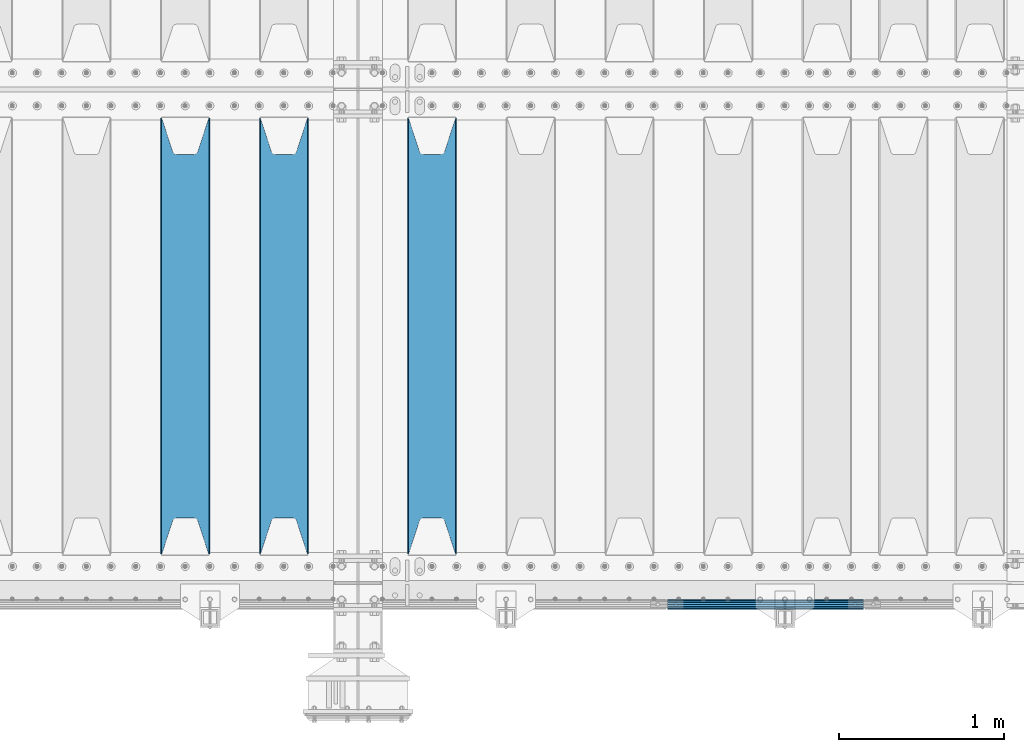
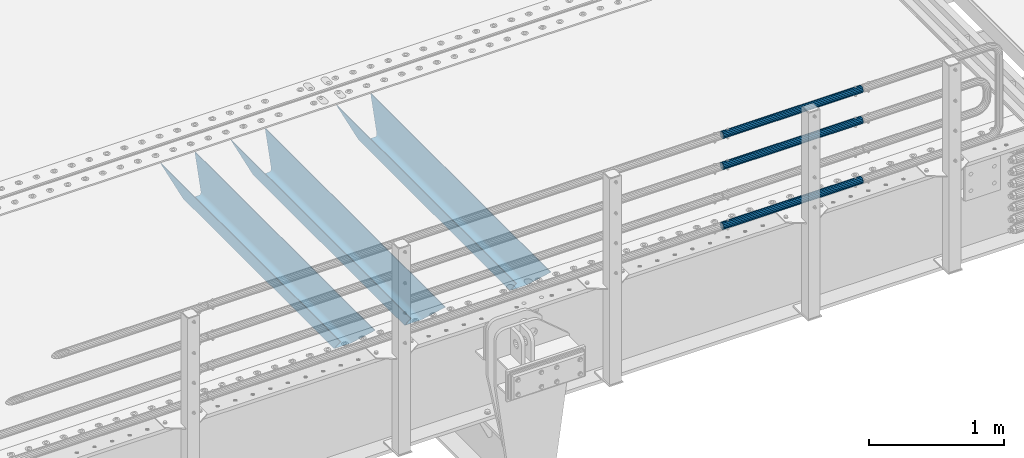
# One storey, part 109 of 257: 6 beams.
"""IFC2X3 building model written with IfcOpenShell, lengths in millimetres."""

from ifc_helpers import new_model, si_unit, frame, origin_with_axes, place, context, subcontext, project, spatial, faceted_brep, material, type_object, element, save


model = new_model("IFC2X3")

# Units and contexts
model_context = context("Model", 3, precision=1e-05, world=origin_with_axes())
body_context = subcontext(model_context, "Body", "Model", "MODEL_VIEW")
ifc_project = project(units=[si_unit("LENGTHUNIT", "METRE", prefix="MILLI"), si_unit("AREAUNIT", "SQUARE_METRE"), si_unit("VOLUMEUNIT", "CUBIC_METRE"), si_unit("MASSUNIT", "GRAM", prefix="KILO"), si_unit("TIMEUNIT", "SECOND"), si_unit("PLANEANGLEUNIT", "RADIAN"), si_unit("SOLIDANGLEUNIT", "STERADIAN"), si_unit("THERMODYNAMICTEMPERATUREUNIT", "DEGREE_CELSIUS"), si_unit("LUMINOUSINTENSITYUNIT", "LUMEN")], contexts=[model_context])

# Site, building, storey
site_placement = place(None, origin_with_axes())
site = spatial("IfcSite", under=ifc_project, at=site_placement, CompositionType="ELEMENT")
building_placement = place(site_placement, origin_with_axes())
building = spatial("IfcBuilding", under=site, at=building_placement, Name="Standard", CompositionType="ELEMENT")
storey_placement = place(building_placement, origin_with_axes())
storey = spatial("IfcBuildingStorey", under=building, at=storey_placement, Name="Undefined", CompositionType="ELEMENT", Elevation=0.0)

# Beams
ifc_material_1 = material(Name="STEEL/S355N")
beam_type_1 = type_object("IfcBeamType", PredefinedType="NOTDEFINED")
beam_1_placement = place(storey_placement, frame((55150.0, 175.0, -115.0), z_axis=(0.0, 0.0, 1.0), x_axis=(0.0, 1.0, 0.0)))
element("IfcBeam", 1, at=beam_1_placement, inside=storey, type_object=beam_type_1, material=ifc_material_1, context=body_context, shape_type="Brep", body=[
    faceted_brep([(0.0, 150.0, 115.0), (0.0, 143.690000000002, 115.0), (2650.00000000297, 143.690000000002, 115.0), (2650.00000000297, 150.0, 115.0), (2650.00000000297, 142.059565218406, 110.0000000031), (2650.00000000297, 148.369565218403, 110.0000000031), (2441.90079219208, -80.1103600731149, -98.0992078077845), (2437.7588105432, -77.5672621345584, -102.241189456673), (2434.06523489746, -74.4080125315522, -105.934765102404), (2430.91086095089, -70.7102721255724, -109.089139048974), (2428.37322971128, -66.5649389910031, -111.626770288588), (2426.51472138055, -62.0739139532889, -113.485278619323), (2425.38102192091, -57.3475956567636, -114.618978078955), (2424.99999999987, -52.5021667386536, -115.0), (2424.99999999987, 52.5021667386536, -115.0), (2425.38102192091, 57.3475956567636, -114.618978078955), (2426.51472138055, 62.0739139532889, -113.485278619323), (2428.37322971128, 66.5649389910031, -111.626770288588), (2430.91086095089, 70.7102721255724, -109.089139048974), (2434.06523489746, 74.4080125315522, -105.934765102404), (2437.7588105432, 77.5672621345584, -102.241189456673), (2441.90079219208, 80.1103600731149, -98.0992078077846), (2446.38936140511, 81.9747917625791, -93.6106385947584), (2448.24948500409, 76.2713538057287, -91.7505149957729), (2444.62967112262, 74.76777986261, -95.3703288772456), (2441.28936334126, 72.7168944282894, -98.710636658607), (2438.31067330438, 70.1691124903809, -101.689326695487), (2435.76682334747, 67.1870637758839, -104.233176652398), (2433.72034654133, 63.8440531834931, -106.279653458539), (2432.22154950041, 60.2222587982324, -107.778450499454), (2431.30727574265, 56.4107117849126, -108.692724257221), (2430.99999999987, 52.5031078186876, -109.0), (2430.99999999987, -52.5031078186876, -109.0), (2431.30727574265, -56.4107117849126, -108.692724257221), (2432.22154950041, -60.2222587982324, -107.778450499454), (2433.72034654133, -63.8440531834931, -106.279653458539), (2435.76682334747, -67.1870637758839, -104.233176652398), (2438.31067330438, -70.1691124903809, -101.689326695487), (2441.28936334126, -72.7168944282894, -98.7106366586071), (2444.62967112262, -74.76777986261, -95.3703288772457), (2448.24948500409, -76.2713538057287, -91.7505149957729), (2650.00000000297, -142.059565218406, 110.0000000031), (2650.00000000297, -148.369565218403, 110.0000000031), (2446.38936140511, -81.9747917625791, -93.6106385947584), (2650.00000000297, -143.690000000002, 115.0), (2650.00000000297, -150.0, 115.0), (0.0, -143.690000000002, 115.0), (0.0, -150.0, 115.0), (0.0, -148.369565218258, 110.000000002662), (203.61063859742, -81.9747917625791, -93.6106385947584), (208.099207810447, -80.1103600731149, -98.0992078077845), (212.241189459335, -77.5672621345584, -102.241189456673), (215.934765105066, -74.4080125315522, -105.934765102404), (219.089139051636, -70.7102721255724, -109.089139048974), (221.626770291251, -66.5649389910031, -111.626770288588), (223.485278621985, -62.0739139532889, -113.485278619323), (224.618978081617, -57.3475956567636, -114.618978078955), (225.000000002662, -52.5021667386536, -115.0), (225.000000002662, 52.5021667386536, -115.0), (224.618978081617, 57.3475956567636, -114.618978078955), (223.485278621985, 62.0739139532889, -113.485278619323), (221.626770291251, 66.5649389910031, -111.626770288588), (219.089139051636, 70.7102721255724, -109.089139048974), (215.934765105066, 74.4080125315522, -105.934765102404), (212.241189459335, 77.5672621345584, -102.241189456673), (208.099207810447, 80.1103600731149, -98.0992078077846), (203.61063859742, 81.9747917625791, -93.6106385947584), (0.0, 148.369565218258, 110.000000002662), (0.0, 142.05956521826, 110.000000002662), (201.750514998435, 76.2713538057287, -91.7505149957729), (205.370328879908, 74.76777986261, -95.3703288772456), (208.710636661269, 72.7168944282894, -98.710636658607), (211.689326698149, 70.1691124903809, -101.689326695487), (214.233176655061, 67.1870637758839, -104.233176652398), (216.279653461201, 63.8440531834931, -106.279653458539), (217.778450502116, 60.2222587982324, -107.778450499454), (218.692724259884, 56.4107117849126, -108.692724257221), (219.000000002662, 52.5031078186876, -109.0), (219.000000002662, -52.5031078186876, -109.0), (218.692724259884, -56.4107117849126, -108.692724257221), (217.778450502116, -60.2222587982324, -107.778450499454), (216.279653461201, -63.8440531834931, -106.279653458539), (214.233176655061, -67.1870637758839, -104.233176652398), (211.689326698149, -70.1691124903809, -101.689326695487), (208.710636661269, -72.7168944282894, -98.7106366586071), (205.370328879908, -74.76777986261, -95.3703288772457), (201.750514998435, -76.2713538057287, -91.7505149957729), (0.0, -142.05956521826, 110.000000002662)], [[[0, 1, 2, 3]], [[3, 2, 4, 5]], [[6, 7, 8, 9, 10, 11, 12, 13, 14, 15, 16, 17, 18, 19, 20, 21, 22, 5, 4, 23, 24, 25, 26, 27, 28, 29, 30, 31, 32, 33, 34, 35, 36, 37, 38, 39, 40, 41, 42, 43]], [[44, 45, 42, 41]], [[46, 47, 45, 44]], [[43, 42, 45, 47, 48, 49]], [[6, 43, 49, 50]], [[7, 6, 50, 51]], [[8, 7, 51, 52]], [[9, 8, 52, 53]], [[10, 9, 53, 54]], [[11, 10, 54, 55]], [[12, 11, 55, 56]], [[13, 12, 56, 57]], [[14, 13, 57, 58]], [[15, 14, 58, 59]], [[16, 15, 59, 60]], [[17, 16, 60, 61]], [[18, 17, 61, 62]], [[19, 18, 62, 63]], [[20, 19, 63, 64]], [[21, 20, 64, 65]], [[22, 21, 65, 66]], [[0, 3, 5, 22, 66, 67]], [[1, 0, 67, 68]], [[23, 4, 2, 1, 68, 69]], [[24, 23, 69, 70]], [[25, 24, 70, 71]], [[26, 25, 71, 72]], [[27, 26, 72, 73]], [[28, 27, 73, 74]], [[29, 28, 74, 75]], [[30, 29, 75, 76]], [[31, 30, 76, 77]], [[32, 31, 77, 78]], [[33, 32, 78, 79]], [[34, 33, 79, 80]], [[35, 34, 80, 81]], [[36, 35, 81, 82]], [[37, 36, 82, 83]], [[38, 37, 83, 84]], [[39, 38, 84, 85]], [[40, 39, 85, 86]], [[46, 44, 41, 40, 86, 87]], [[47, 46, 87, 48]], [[86, 85, 84, 83, 82, 81, 80, 79, 78, 77, 76, 75, 74, 73, 72, 71, 70, 69, 68, 67, 66, 65, 64, 63, 62, 61, 60, 59, 58, 57, 56, 55, 54, 53, 52, 51, 50, 49, 48, 87]]]),
])
beam_2_placement = place(storey_placement, frame((54250.0, 175.0, -115.0), z_axis=(0.0, 0.0, 1.0), x_axis=(0.0, 1.0, 0.0)))
element("IfcBeam", 2, at=beam_2_placement, inside=storey, type_object=beam_type_1, material=ifc_material_1, context=body_context, shape_type="Brep", body=[
    faceted_brep([(0.0, 150.0, 115.0), (0.0, 143.690000000002, 115.0), (2650.00000000297, 143.690000000002, 115.0), (2650.00000000297, 150.0, 115.0), (2650.00000000297, 142.059565218406, 110.0000000031), (2650.00000000297, 148.369565218403, 110.0000000031), (2441.90079219208, -80.1103600731149, -98.0992078077845), (2437.7588105432, -77.5672621345584, -102.241189456673), (2434.06523489746, -74.4080125315522, -105.934765102404), (2430.91086095089, -70.7102721255724, -109.089139048974), (2428.37322971128, -66.5649389910031, -111.626770288588), (2426.51472138055, -62.0739139532889, -113.485278619323), (2425.38102192091, -57.3475956567636, -114.618978078955), (2424.99999999987, -52.5021667386536, -115.0), (2424.99999999987, 52.5021667386536, -115.0), (2425.38102192091, 57.3475956567636, -114.618978078955), (2426.51472138055, 62.0739139532889, -113.485278619323), (2428.37322971128, 66.5649389910031, -111.626770288588), (2430.91086095089, 70.7102721255724, -109.089139048974), (2434.06523489746, 74.4080125315522, -105.934765102404), (2437.7588105432, 77.5672621345584, -102.241189456673), (2441.90079219208, 80.1103600731149, -98.0992078077846), (2446.38936140511, 81.9747917625791, -93.6106385947584), (2448.24948500409, 76.2713538057287, -91.7505149957729), (2444.62967112262, 74.76777986261, -95.3703288772456), (2441.28936334126, 72.7168944282894, -98.710636658607), (2438.31067330438, 70.1691124903809, -101.689326695487), (2435.76682334747, 67.1870637758839, -104.233176652398), (2433.72034654133, 63.8440531834931, -106.279653458539), (2432.22154950041, 60.2222587982324, -107.778450499454), (2431.30727574265, 56.4107117849126, -108.692724257221), (2430.99999999987, 52.5031078186876, -109.0), (2430.99999999987, -52.5031078186876, -109.0), (2431.30727574265, -56.4107117849126, -108.692724257221), (2432.22154950041, -60.2222587982324, -107.778450499454), (2433.72034654133, -63.8440531834931, -106.279653458539), (2435.76682334747, -67.1870637758839, -104.233176652398), (2438.31067330438, -70.1691124903809, -101.689326695487), (2441.28936334126, -72.7168944282894, -98.7106366586071), (2444.62967112262, -74.76777986261, -95.3703288772457), (2448.24948500409, -76.2713538057287, -91.7505149957729), (2650.00000000297, -142.059565218406, 110.0000000031), (2650.00000000297, -148.369565218403, 110.0000000031), (2446.38936140511, -81.9747917625791, -93.6106385947584), (2650.00000000297, -143.690000000002, 115.0), (2650.00000000297, -150.0, 115.0), (0.0, -143.690000000002, 115.0), (0.0, -150.0, 115.0), (0.0, -148.369565218258, 110.000000002662), (203.61063859742, -81.9747917625791, -93.6106385947584), (208.099207810447, -80.1103600731149, -98.0992078077845), (212.241189459335, -77.5672621345584, -102.241189456673), (215.934765105066, -74.4080125315522, -105.934765102404), (219.089139051636, -70.7102721255724, -109.089139048974), (221.626770291251, -66.5649389910031, -111.626770288588), (223.485278621985, -62.0739139532889, -113.485278619323), (224.618978081617, -57.3475956567636, -114.618978078955), (225.000000002662, -52.5021667386536, -115.0), (225.000000002662, 52.5021667386536, -115.0), (224.618978081617, 57.3475956567636, -114.618978078955), (223.485278621985, 62.0739139532889, -113.485278619323), (221.626770291251, 66.5649389910031, -111.626770288588), (219.089139051636, 70.7102721255724, -109.089139048974), (215.934765105066, 74.4080125315522, -105.934765102404), (212.241189459335, 77.5672621345584, -102.241189456673), (208.099207810447, 80.1103600731149, -98.0992078077846), (203.61063859742, 81.9747917625791, -93.6106385947584), (0.0, 148.369565218258, 110.000000002662), (0.0, 142.05956521826, 110.000000002662), (201.750514998435, 76.2713538057287, -91.7505149957729), (205.370328879908, 74.76777986261, -95.3703288772456), (208.710636661269, 72.7168944282894, -98.710636658607), (211.689326698149, 70.1691124903809, -101.689326695487), (214.233176655061, 67.1870637758839, -104.233176652398), (216.279653461201, 63.8440531834931, -106.279653458539), (217.778450502116, 60.2222587982324, -107.778450499454), (218.692724259884, 56.4107117849126, -108.692724257221), (219.000000002662, 52.5031078186876, -109.0), (219.000000002662, -52.5031078186876, -109.0), (218.692724259884, -56.4107117849126, -108.692724257221), (217.778450502116, -60.2222587982324, -107.778450499454), (216.279653461201, -63.8440531834931, -106.279653458539), (214.233176655061, -67.1870637758839, -104.233176652398), (211.689326698149, -70.1691124903809, -101.689326695487), (208.710636661269, -72.7168944282894, -98.7106366586071), (205.370328879908, -74.76777986261, -95.3703288772457), (201.750514998435, -76.2713538057287, -91.7505149957729), (0.0, -142.05956521826, 110.000000002662)], [[[0, 1, 2, 3]], [[3, 2, 4, 5]], [[6, 7, 8, 9, 10, 11, 12, 13, 14, 15, 16, 17, 18, 19, 20, 21, 22, 5, 4, 23, 24, 25, 26, 27, 28, 29, 30, 31, 32, 33, 34, 35, 36, 37, 38, 39, 40, 41, 42, 43]], [[44, 45, 42, 41]], [[46, 47, 45, 44]], [[43, 42, 45, 47, 48, 49]], [[6, 43, 49, 50]], [[7, 6, 50, 51]], [[8, 7, 51, 52]], [[9, 8, 52, 53]], [[10, 9, 53, 54]], [[11, 10, 54, 55]], [[12, 11, 55, 56]], [[13, 12, 56, 57]], [[14, 13, 57, 58]], [[15, 14, 58, 59]], [[16, 15, 59, 60]], [[17, 16, 60, 61]], [[18, 17, 61, 62]], [[19, 18, 62, 63]], [[20, 19, 63, 64]], [[21, 20, 64, 65]], [[22, 21, 65, 66]], [[0, 3, 5, 22, 66, 67]], [[1, 0, 67, 68]], [[23, 4, 2, 1, 68, 69]], [[24, 23, 69, 70]], [[25, 24, 70, 71]], [[26, 25, 71, 72]], [[27, 26, 72, 73]], [[28, 27, 73, 74]], [[29, 28, 74, 75]], [[30, 29, 75, 76]], [[31, 30, 76, 77]], [[32, 31, 77, 78]], [[33, 32, 78, 79]], [[34, 33, 79, 80]], [[35, 34, 80, 81]], [[36, 35, 81, 82]], [[37, 36, 82, 83]], [[38, 37, 83, 84]], [[39, 38, 84, 85]], [[40, 39, 85, 86]], [[46, 44, 41, 40, 86, 87]], [[47, 46, 87, 48]], [[86, 85, 84, 83, 82, 81, 80, 79, 78, 77, 76, 75, 74, 73, 72, 71, 70, 69, 68, 67, 66, 65, 64, 63, 62, 61, 60, 59, 58, 57, 56, 55, 54, 53, 52, 51, 50, 49, 48, 87]]]),
])
beam_3_placement = place(storey_placement, frame((53650.0, 175.0, -115.0), z_axis=(0.0, 0.0, 1.0), x_axis=(0.0, 1.0, 0.0)))
element("IfcBeam", 3, at=beam_3_placement, inside=storey, type_object=beam_type_1, material=ifc_material_1, context=body_context, shape_type="Brep", body=[
    faceted_brep([(0.0, 150.0, 115.0), (0.0, 143.690000000002, 115.0), (2650.00000000297, 143.690000000002, 115.0), (2650.00000000297, 150.0, 115.0), (2650.00000000297, 142.059565218406, 110.0000000031), (2650.00000000297, 148.369565218403, 110.0000000031), (2441.90079219208, -80.1103600731149, -98.0992078077845), (2437.7588105432, -77.5672621345584, -102.241189456673), (2434.06523489746, -74.4080125315522, -105.934765102404), (2430.91086095089, -70.7102721255724, -109.089139048974), (2428.37322971128, -66.5649389910031, -111.626770288588), (2426.51472138055, -62.0739139532889, -113.485278619323), (2425.38102192091, -57.3475956567636, -114.618978078955), (2424.99999999987, -52.5021667386536, -115.0), (2424.99999999987, 52.5021667386536, -115.0), (2425.38102192091, 57.3475956567636, -114.618978078955), (2426.51472138055, 62.0739139532889, -113.485278619323), (2428.37322971128, 66.5649389910031, -111.626770288588), (2430.91086095089, 70.7102721255724, -109.089139048974), (2434.06523489746, 74.4080125315522, -105.934765102404), (2437.7588105432, 77.5672621345584, -102.241189456673), (2441.90079219208, 80.1103600731149, -98.0992078077846), (2446.38936140511, 81.9747917625791, -93.6106385947584), (2448.24948500409, 76.2713538057287, -91.7505149957729), (2444.62967112262, 74.76777986261, -95.3703288772456), (2441.28936334126, 72.7168944282894, -98.710636658607), (2438.31067330438, 70.1691124903809, -101.689326695487), (2435.76682334747, 67.1870637758839, -104.233176652398), (2433.72034654133, 63.8440531834931, -106.279653458539), (2432.22154950041, 60.2222587982324, -107.778450499454), (2431.30727574265, 56.4107117849126, -108.692724257221), (2430.99999999987, 52.5031078186876, -109.0), (2430.99999999987, -52.5031078186876, -109.0), (2431.30727574265, -56.4107117849126, -108.692724257221), (2432.22154950041, -60.2222587982324, -107.778450499454), (2433.72034654133, -63.8440531834931, -106.279653458539), (2435.76682334747, -67.1870637758839, -104.233176652398), (2438.31067330438, -70.1691124903809, -101.689326695487), (2441.28936334126, -72.7168944282894, -98.7106366586071), (2444.62967112262, -74.76777986261, -95.3703288772457), (2448.24948500409, -76.2713538057287, -91.7505149957729), (2650.00000000297, -142.059565218406, 110.0000000031), (2650.00000000297, -148.369565218403, 110.0000000031), (2446.38936140511, -81.9747917625791, -93.6106385947584), (2650.00000000297, -143.690000000002, 115.0), (2650.00000000297, -150.0, 115.0), (0.0, -143.690000000002, 115.0), (0.0, -150.0, 115.0), (0.0, -148.369565218258, 110.000000002662), (203.61063859742, -81.9747917625791, -93.6106385947584), (208.099207810447, -80.1103600731149, -98.0992078077845), (212.241189459335, -77.5672621345584, -102.241189456673), (215.934765105066, -74.4080125315522, -105.934765102404), (219.089139051636, -70.7102721255724, -109.089139048974), (221.626770291251, -66.5649389910031, -111.626770288588), (223.485278621985, -62.0739139532889, -113.485278619323), (224.618978081617, -57.3475956567636, -114.618978078955), (225.000000002662, -52.5021667386536, -115.0), (225.000000002662, 52.5021667386536, -115.0), (224.618978081617, 57.3475956567636, -114.618978078955), (223.485278621985, 62.0739139532889, -113.485278619323), (221.626770291251, 66.5649389910031, -111.626770288588), (219.089139051636, 70.7102721255724, -109.089139048974), (215.934765105066, 74.4080125315522, -105.934765102404), (212.241189459335, 77.5672621345584, -102.241189456673), (208.099207810447, 80.1103600731149, -98.0992078077846), (203.61063859742, 81.9747917625791, -93.6106385947584), (0.0, 148.369565218258, 110.000000002662), (0.0, 142.05956521826, 110.000000002662), (201.750514998435, 76.2713538057287, -91.7505149957729), (205.370328879908, 74.76777986261, -95.3703288772456), (208.710636661269, 72.7168944282894, -98.710636658607), (211.689326698149, 70.1691124903809, -101.689326695487), (214.233176655061, 67.1870637758839, -104.233176652398), (216.279653461201, 63.8440531834931, -106.279653458539), (217.778450502116, 60.2222587982324, -107.778450499454), (218.692724259884, 56.4107117849126, -108.692724257221), (219.000000002662, 52.5031078186876, -109.0), (219.000000002662, -52.5031078186876, -109.0), (218.692724259884, -56.4107117849126, -108.692724257221), (217.778450502116, -60.2222587982324, -107.778450499454), (216.279653461201, -63.8440531834931, -106.279653458539), (214.233176655061, -67.1870637758839, -104.233176652398), (211.689326698149, -70.1691124903809, -101.689326695487), (208.710636661269, -72.7168944282894, -98.7106366586071), (205.370328879908, -74.76777986261, -95.3703288772457), (201.750514998435, -76.2713538057287, -91.7505149957729), (0.0, -142.05956521826, 110.000000002662)], [[[0, 1, 2, 3]], [[3, 2, 4, 5]], [[6, 7, 8, 9, 10, 11, 12, 13, 14, 15, 16, 17, 18, 19, 20, 21, 22, 5, 4, 23, 24, 25, 26, 27, 28, 29, 30, 31, 32, 33, 34, 35, 36, 37, 38, 39, 40, 41, 42, 43]], [[44, 45, 42, 41]], [[46, 47, 45, 44]], [[43, 42, 45, 47, 48, 49]], [[6, 43, 49, 50]], [[7, 6, 50, 51]], [[8, 7, 51, 52]], [[9, 8, 52, 53]], [[10, 9, 53, 54]], [[11, 10, 54, 55]], [[12, 11, 55, 56]], [[13, 12, 56, 57]], [[14, 13, 57, 58]], [[15, 14, 58, 59]], [[16, 15, 59, 60]], [[17, 16, 60, 61]], [[18, 17, 61, 62]], [[19, 18, 62, 63]], [[20, 19, 63, 64]], [[21, 20, 64, 65]], [[22, 21, 65, 66]], [[0, 3, 5, 22, 66, 67]], [[1, 0, 67, 68]], [[23, 4, 2, 1, 68, 69]], [[24, 23, 69, 70]], [[25, 24, 70, 71]], [[26, 25, 71, 72]], [[27, 26, 72, 73]], [[28, 27, 73, 74]], [[29, 28, 74, 75]], [[30, 29, 75, 76]], [[31, 30, 76, 77]], [[32, 31, 77, 78]], [[33, 32, 78, 79]], [[34, 33, 79, 80]], [[35, 34, 80, 81]], [[36, 35, 81, 82]], [[37, 36, 82, 83]], [[38, 37, 83, 84]], [[39, 38, 84, 85]], [[40, 39, 85, 86]], [[46, 44, 41, 40, 86, 87]], [[47, 46, 87, 48]], [[86, 85, 84, 83, 82, 81, 80, 79, 78, 77, 76, 75, 74, 73, 72, 71, 70, 69, 68, 67, 66, 65, 64, 63, 62, 61, 60, 59, 58, 57, 56, 55, 54, 53, 52, 51, 50, 49, 48, 87]]]),
])
ifc_material_2 = material()
beam_type_2 = type_object("IfcBeamType", PredefinedType="NOTDEFINED")
beam_4_placement = place(storey_placement, frame((56582.0000000001, -129.850000000402, 149.549999999726), z_axis=(0.0, -1.0, 0.0), x_axis=(1.0, 0.0, 0.0)))
element("IfcBeam", 4, at=beam_4_placement, inside=storey, type_object=beam_type_2, material=ifc_material_2, context=body_context, shape_type="Brep", body=[
    faceted_brep([(0.0, -26.5499999999993, 0.0), (0.0, -24.5290015881747, 10.1602451292931), (1190.0, -24.5290015881747, 10.1602451292929), (1190.0, -26.55, 0.0), (0.0, -18.7736850405036, 18.7736850405028), (1190.0, -18.7736850405028, 18.7736850405036), (0.0, -10.1602451292929, 24.5290015881747), (1190.0, -10.1602451292931, 24.5290015881747), (0.0, 0.0, 26.55), (1190.0, 0.0, 26.5499999999993), (0.0, 10.1602451292929, 24.5290015881747), (1190.0, 10.1602451292932, 24.5290015881747), (0.0, 18.7736850405036, 18.7736850405028), (1190.0, 18.7736850405029, 18.7736850405036), (0.0, 24.5290015881747, 10.1602451292931), (1190.0, 24.5290015881747, 10.1602451292929), (0.0, 26.5499999999993, 0.0), (1190.0, 26.55, 0.0), (0.0, 24.5290015881747, -10.1602451292931), (1190.0, 24.5290015881747, -10.1602451292929), (0.0, 18.7736850405036, -18.7736850405028), (1190.0, 18.7736850405028, -18.7736850405036), (0.0, 10.1602451292929, -24.5290015881747), (1190.0, 10.1602451292931, -24.5290015881747), (0.0, 0.0, -26.55), (1190.0, 0.0, -26.5499999999993), (0.0, -10.1602451292929, -24.5290015881747), (1190.0, -10.1602451292931, -24.5290015881747), (0.0, -18.7736850405036, -18.7736850405028), (1190.0, -18.7736850405028, -18.7736850405036), (0.0, -24.5290015881747, -10.1602451292931), (1190.0, -24.5290015881747, -10.1602451292929), (0.0, -30.1499999999996, 0.0), (0.0, -27.8549679052157, -11.5379054858058), (1190.0, -27.8549679052153, -11.5379054858076), (1190.0, -30.15, 0.0), (0.0, -21.3192694527752, -21.3192694527752), (1190.0, -21.3192694527744, -21.3192694527752), (0.0, -11.5379054858076, -27.8549679052157), (1190.0, -11.5379054858075, -27.8549679052157), (0.0, 0.0, -30.1500000000015), (1190.0, 0.0, -30.1499999999996), (0.0, 11.5379054858076, -27.8549679052157), (1190.0, 11.5379054858075, -27.8549679052157), (0.0, 21.3192694527752, -21.3192694527752), (1190.0, 21.3192694527744, -21.3192694527752), (0.0, 27.8549679052157, -11.5379054858058), (1190.0, 27.8549679052153, -11.5379054858076), (0.0, 30.1499999999996, 0.0), (1190.0, 30.15, 0.0), (0.0, 27.8549679052157, 11.5379054858058), (1190.0, 27.8549679052153, 11.5379054858076), (0.0, 21.3192694527752, 21.3192694527752), (1190.0, 21.3192694527744, 21.3192694527752), (0.0, 11.5379054858076, 27.8549679052157), (1190.0, 11.5379054858075, 27.8549679052157), (0.0, 0.0, 30.1500000000015), (1190.0, 0.0, 30.1499999999996), (0.0, -11.5379054858076, 27.8549679052157), (1190.0, -11.5379054858075, 27.8549679052157), (0.0, -21.3192694527752, 21.3192694527752), (1190.0, -21.3192694527744, 21.3192694527752), (0.0, -27.8549679052157, 11.5379054858058), (1190.0, -27.8549679052153, 11.5379054858076)], [[[0, 1, 2, 3]], [[1, 4, 5, 2]], [[4, 6, 7, 5]], [[6, 8, 9, 7]], [[8, 10, 11, 9]], [[10, 12, 13, 11]], [[12, 14, 15, 13]], [[14, 16, 17, 15]], [[16, 18, 19, 17]], [[18, 20, 21, 19]], [[20, 22, 23, 21]], [[22, 24, 25, 23]], [[24, 26, 27, 25]], [[26, 28, 29, 27]], [[28, 30, 31, 29]], [[30, 0, 3, 31]], [[32, 33, 34, 35]], [[33, 36, 37, 34]], [[36, 38, 39, 37]], [[38, 40, 41, 39]], [[40, 42, 43, 41]], [[42, 44, 45, 43]], [[44, 46, 47, 45]], [[46, 48, 49, 47]], [[48, 50, 51, 49]], [[50, 52, 53, 51]], [[52, 54, 55, 53]], [[54, 56, 57, 55]], [[56, 58, 59, 57]], [[58, 60, 61, 59]], [[60, 62, 63, 61]], [[62, 32, 35, 63]], [[37, 39, 41, 43, 45, 47, 49, 51, 53, 55, 57, 59, 61, 63, 35, 34], [5, 7, 9, 11, 13, 15, 17, 19, 21, 23, 25, 27, 29, 31, 3, 2]], [[62, 60, 58, 56, 54, 52, 50, 48, 46, 44, 42, 40, 38, 36, 33, 32], [30, 28, 26, 24, 22, 20, 18, 16, 14, 12, 10, 8, 6, 4, 1, 0]]]),
])
beam_5_placement = place(storey_placement, frame((56582.0000000001, -129.850000000402, 969.549999999726), z_axis=(0.0, -1.0, 0.0), x_axis=(1.0, 0.0, 0.0)))
element("IfcBeam", 5, at=beam_5_placement, inside=storey, type_object=beam_type_2, material=ifc_material_2, context=body_context, shape_type="Brep", body=[
    faceted_brep([(0.0, -26.5499999999993, 0.0), (0.0, -24.5290015881747, 10.1602451292931), (1190.0, -24.5290015881747, 10.1602451292929), (1190.0, -26.55, 0.0), (0.0, -18.7736850405036, 18.7736850405028), (1190.0, -18.7736850405028, 18.7736850405036), (0.0, -10.1602451292929, 24.5290015881747), (1190.0, -10.1602451292931, 24.5290015881747), (0.0, 0.0, 26.55), (1190.0, 0.0, 26.5499999999993), (0.0, 10.1602451292929, 24.5290015881747), (1190.0, 10.1602451292932, 24.5290015881747), (0.0, 18.7736850405036, 18.7736850405028), (1190.0, 18.7736850405029, 18.7736850405036), (0.0, 24.5290015881747, 10.1602451292931), (1190.0, 24.5290015881747, 10.1602451292929), (0.0, 26.5499999999993, 0.0), (1190.0, 26.55, 0.0), (0.0, 24.5290015881747, -10.1602451292931), (1190.0, 24.5290015881747, -10.1602451292929), (0.0, 18.7736850405036, -18.7736850405028), (1190.0, 18.7736850405028, -18.7736850405036), (0.0, 10.1602451292929, -24.5290015881747), (1190.0, 10.1602451292931, -24.5290015881747), (0.0, 0.0, -26.55), (1190.0, 0.0, -26.5499999999993), (0.0, -10.1602451292929, -24.5290015881747), (1190.0, -10.1602451292931, -24.5290015881747), (0.0, -18.7736850405036, -18.7736850405028), (1190.0, -18.7736850405028, -18.7736850405036), (0.0, -24.5290015881747, -10.1602451292931), (1190.0, -24.5290015881747, -10.1602451292929), (0.0, -30.1499999999996, 0.0), (0.0, -27.8549679052157, -11.5379054858058), (1190.0, -27.8549679052153, -11.5379054858076), (1190.0, -30.15, 0.0), (0.0, -21.3192694527752, -21.3192694527752), (1190.0, -21.3192694527744, -21.3192694527752), (0.0, -11.5379054858076, -27.8549679052157), (1190.0, -11.5379054858075, -27.8549679052157), (0.0, 0.0, -30.1500000000015), (1190.0, 0.0, -30.1499999999996), (0.0, 11.5379054858076, -27.8549679052157), (1190.0, 11.5379054858075, -27.8549679052157), (0.0, 21.3192694527752, -21.3192694527752), (1190.0, 21.3192694527744, -21.3192694527752), (0.0, 27.8549679052157, -11.5379054858058), (1190.0, 27.8549679052153, -11.5379054858076), (0.0, 30.1499999999996, 0.0), (1190.0, 30.15, 0.0), (0.0, 27.8549679052157, 11.5379054858058), (1190.0, 27.8549679052153, 11.5379054858076), (0.0, 21.3192694527752, 21.3192694527752), (1190.0, 21.3192694527744, 21.3192694527752), (0.0, 11.5379054858076, 27.8549679052157), (1190.0, 11.5379054858075, 27.8549679052157), (0.0, 0.0, 30.1500000000015), (1190.0, 0.0, 30.1499999999996), (0.0, -11.5379054858076, 27.8549679052157), (1190.0, -11.5379054858075, 27.8549679052157), (0.0, -21.3192694527752, 21.3192694527752), (1190.0, -21.3192694527744, 21.3192694527752), (0.0, -27.8549679052157, 11.5379054858058), (1190.0, -27.8549679052153, 11.5379054858076)], [[[0, 1, 2, 3]], [[1, 4, 5, 2]], [[4, 6, 7, 5]], [[6, 8, 9, 7]], [[8, 10, 11, 9]], [[10, 12, 13, 11]], [[12, 14, 15, 13]], [[14, 16, 17, 15]], [[16, 18, 19, 17]], [[18, 20, 21, 19]], [[20, 22, 23, 21]], [[22, 24, 25, 23]], [[24, 26, 27, 25]], [[26, 28, 29, 27]], [[28, 30, 31, 29]], [[30, 0, 3, 31]], [[32, 33, 34, 35]], [[33, 36, 37, 34]], [[36, 38, 39, 37]], [[38, 40, 41, 39]], [[40, 42, 43, 41]], [[42, 44, 45, 43]], [[44, 46, 47, 45]], [[46, 48, 49, 47]], [[48, 50, 51, 49]], [[50, 52, 53, 51]], [[52, 54, 55, 53]], [[54, 56, 57, 55]], [[56, 58, 59, 57]], [[58, 60, 61, 59]], [[60, 62, 63, 61]], [[62, 32, 35, 63]], [[37, 39, 41, 43, 45, 47, 49, 51, 53, 55, 57, 59, 61, 63, 35, 34], [5, 7, 9, 11, 13, 15, 17, 19, 21, 23, 25, 27, 29, 31, 3, 2]], [[62, 60, 58, 56, 54, 52, 50, 48, 46, 44, 42, 40, 38, 36, 33, 32], [30, 28, 26, 24, 22, 20, 18, 16, 14, 12, 10, 8, 6, 4, 1, 0]]]),
])
beam_6_placement = place(storey_placement, frame((56582.0000000001, -129.850000000402, 689.549999999726), z_axis=(0.0, -1.0, 0.0), x_axis=(1.0, 0.0, 0.0)))
element("IfcBeam", 6, at=beam_6_placement, inside=storey, type_object=beam_type_2, material=ifc_material_2, context=body_context, shape_type="Brep", body=[
    faceted_brep([(0.0, -26.5499999999993, 0.0), (0.0, -24.5290015881747, 10.1602451292931), (1190.0, -24.5290015881747, 10.1602451292929), (1190.0, -26.55, 0.0), (0.0, -18.7736850405036, 18.7736850405028), (1190.0, -18.7736850405028, 18.7736850405036), (0.0, -10.1602451292929, 24.5290015881747), (1190.0, -10.1602451292931, 24.5290015881747), (0.0, 0.0, 26.55), (1190.0, 0.0, 26.5499999999993), (0.0, 10.1602451292929, 24.5290015881747), (1190.0, 10.1602451292932, 24.5290015881747), (0.0, 18.7736850405036, 18.7736850405028), (1190.0, 18.7736850405029, 18.7736850405036), (0.0, 24.5290015881747, 10.1602451292931), (1190.0, 24.5290015881747, 10.1602451292929), (0.0, 26.5499999999993, 0.0), (1190.0, 26.55, 0.0), (0.0, 24.5290015881747, -10.1602451292931), (1190.0, 24.5290015881747, -10.1602451292929), (0.0, 18.7736850405036, -18.7736850405028), (1190.0, 18.7736850405028, -18.7736850405036), (0.0, 10.1602451292929, -24.5290015881747), (1190.0, 10.1602451292931, -24.5290015881747), (0.0, 0.0, -26.55), (1190.0, 0.0, -26.5499999999993), (0.0, -10.1602451292929, -24.5290015881747), (1190.0, -10.1602451292931, -24.5290015881747), (0.0, -18.7736850405036, -18.7736850405028), (1190.0, -18.7736850405028, -18.7736850405036), (0.0, -24.5290015881747, -10.1602451292931), (1190.0, -24.5290015881747, -10.1602451292929), (0.0, -30.1499999999996, 0.0), (0.0, -27.8549679052157, -11.5379054858058), (1190.0, -27.8549679052153, -11.5379054858076), (1190.0, -30.15, 0.0), (0.0, -21.3192694527752, -21.3192694527752), (1190.0, -21.3192694527744, -21.3192694527752), (0.0, -11.5379054858076, -27.8549679052157), (1190.0, -11.5379054858075, -27.8549679052157), (0.0, 0.0, -30.1500000000015), (1190.0, 0.0, -30.1499999999996), (0.0, 11.5379054858076, -27.8549679052157), (1190.0, 11.5379054858075, -27.8549679052157), (0.0, 21.3192694527752, -21.3192694527752), (1190.0, 21.3192694527744, -21.3192694527752), (0.0, 27.8549679052157, -11.5379054858058), (1190.0, 27.8549679052153, -11.5379054858076), (0.0, 30.1499999999996, 0.0), (1190.0, 30.15, 0.0), (0.0, 27.8549679052157, 11.5379054858058), (1190.0, 27.8549679052153, 11.5379054858076), (0.0, 21.3192694527752, 21.3192694527752), (1190.0, 21.3192694527744, 21.3192694527752), (0.0, 11.5379054858076, 27.8549679052157), (1190.0, 11.5379054858075, 27.8549679052157), (0.0, 0.0, 30.1500000000015), (1190.0, 0.0, 30.1499999999996), (0.0, -11.5379054858076, 27.8549679052157), (1190.0, -11.5379054858075, 27.8549679052157), (0.0, -21.3192694527752, 21.3192694527752), (1190.0, -21.3192694527744, 21.3192694527752), (0.0, -27.8549679052157, 11.5379054858058), (1190.0, -27.8549679052153, 11.5379054858076)], [[[0, 1, 2, 3]], [[1, 4, 5, 2]], [[4, 6, 7, 5]], [[6, 8, 9, 7]], [[8, 10, 11, 9]], [[10, 12, 13, 11]], [[12, 14, 15, 13]], [[14, 16, 17, 15]], [[16, 18, 19, 17]], [[18, 20, 21, 19]], [[20, 22, 23, 21]], [[22, 24, 25, 23]], [[24, 26, 27, 25]], [[26, 28, 29, 27]], [[28, 30, 31, 29]], [[30, 0, 3, 31]], [[32, 33, 34, 35]], [[33, 36, 37, 34]], [[36, 38, 39, 37]], [[38, 40, 41, 39]], [[40, 42, 43, 41]], [[42, 44, 45, 43]], [[44, 46, 47, 45]], [[46, 48, 49, 47]], [[48, 50, 51, 49]], [[50, 52, 53, 51]], [[52, 54, 55, 53]], [[54, 56, 57, 55]], [[56, 58, 59, 57]], [[58, 60, 61, 59]], [[60, 62, 63, 61]], [[62, 32, 35, 63]], [[37, 39, 41, 43, 45, 47, 49, 51, 53, 55, 57, 59, 61, 63, 35, 34], [5, 7, 9, 11, 13, 15, 17, 19, 21, 23, 25, 27, 29, 31, 3, 2]], [[62, 60, 58, 56, 54, 52, 50, 48, 46, 44, 42, 40, 38, 36, 33, 32], [30, 28, 26, 24, 22, 20, 18, 16, 14, 12, 10, 8, 6, 4, 1, 0]]]),
])

save(model, "model.ifc")
